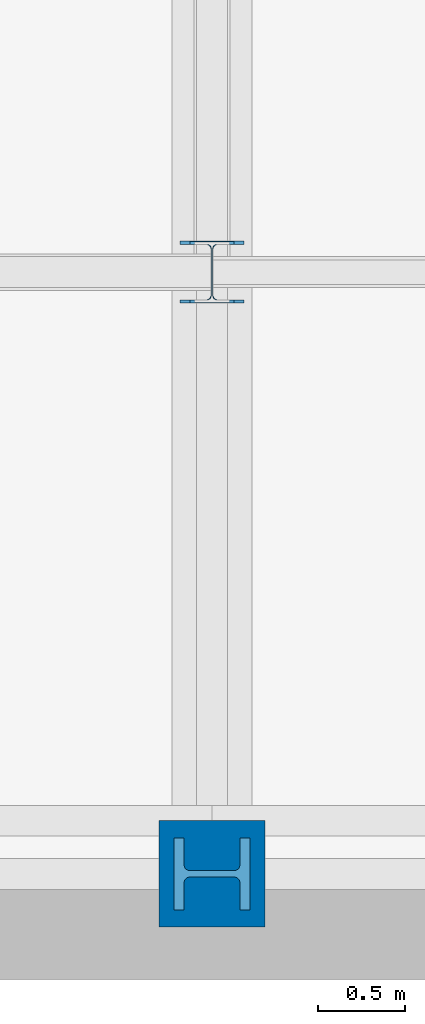
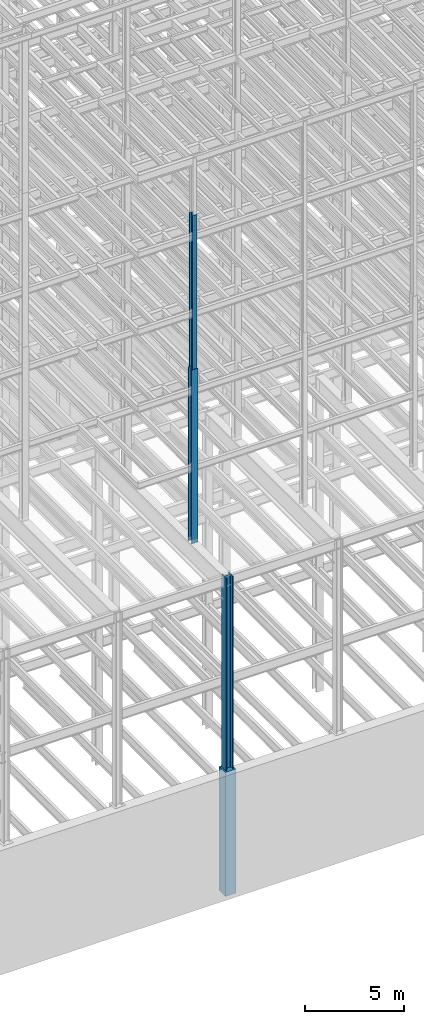
# One storey, part 3 of 150: 4 columns.
"""IFC2X3 building model written with IfcOpenShell, lengths in millimetres."""

from ifc_helpers import new_model, si_unit, frame, origin_with_axes, origin_2d_with_axis, place, context, subcontext, project, spatial, rectangle, i_section, extrude, material, type_object, element, save


model = new_model("IFC2X3")

# Units and contexts
model_context = context("Model", 3, precision=1e-05, world=origin_with_axes())
body_context = subcontext(model_context, "Body", "Model", "MODEL_VIEW")
ifc_project = project(units=[si_unit("LENGTHUNIT", "METRE", prefix="MILLI"), si_unit("AREAUNIT", "SQUARE_METRE"), si_unit("VOLUMEUNIT", "CUBIC_METRE"), si_unit("MASSUNIT", "GRAM", prefix="KILO"), si_unit("TIMEUNIT", "SECOND"), si_unit("PLANEANGLEUNIT", "RADIAN"), si_unit("SOLIDANGLEUNIT", "STERADIAN"), si_unit("THERMODYNAMICTEMPERATUREUNIT", "DEGREE_CELSIUS"), si_unit("LUMINOUSINTENSITYUNIT", "LUMEN")], contexts=[model_context])

# Site, building, storey
site_placement = place(None, origin_with_axes())
site = spatial("IfcSite", under=ifc_project, at=site_placement, CompositionType="ELEMENT")
building_placement = place(site_placement, origin_with_axes())
building = spatial("IfcBuilding", under=site, at=building_placement, Name="Undefined", CompositionType="ELEMENT")
storey_placement = place(building_placement, origin_with_axes())
storey = spatial("IfcBuildingStorey", under=building, at=storey_placement, Name="Undefined", CompositionType="ELEMENT", Elevation=0.0)

# Columns
ifc_material_1 = material(Name="STEEL/A992")
column_type_1 = type_object("IfcColumnType", Name="W14X61", PredefinedType="NOTDEFINED")
column_1_placement = place(storey_placement, frame((18186.4, 3454.4, 46253.4), z_axis=(0.0, 0.0, 1.0), x_axis=(1.0, 0.0, 0.0)))
element("IfcColumn", 1, at=column_1_placement, inside=storey, type_object=column_type_1, material=ifc_material_1, Name="COLUMN", ObjectType="W14X61", context=body_context, shape_type="SweptSolid", body=[
    extrude(i_section(OverallWidth=254.0, OverallDepth=352.425, WebThickness=9.5249, FlangeThickness=16.383, FilletRadius=21.717, at=origin_2d_with_axis()), frame((0.0, 0.0, 9448.8), z_axis=(0.0, 0.0, -1.0), x_axis=(-1.0, 0.0, 0.0)), (0.0, 0.0, 1.0), 9448.8),
])
column_type_2 = type_object("IfcColumnType", Name="W14X311", PredefinedType="NOTDEFINED")
column_2_placement = place(storey_placement, frame((18186.4, 0.0, 22707.6), z_axis=(0.0, 0.0, 1.0), x_axis=(1.0, 0.0, 0.0)))
element("IfcColumn", 2, at=column_2_placement, inside=storey, type_object=column_type_2, material=ifc_material_1, Name="COLUMN", ObjectType="W14X311", context=body_context, shape_type="SweptSolid", body=[
    extrude(i_section(OverallWidth=412.75, OverallDepth=434.975, WebThickness=36.5125, FlangeThickness=57.404, FilletRadius=33.0834, at=origin_2d_with_axis()), frame((0.0, 0.0, 12877.8), z_axis=(0.0, 0.0, -1.0), x_axis=(0.0, -1.0, 0.0)), (0.0, 0.0, 1.0), 12877.8),
])
column_type_3 = type_object("IfcColumnType", Name="W14X90", PredefinedType="NOTDEFINED")
column_3_placement = place(storey_placement, frame((18186.4, 3454.4, 35585.4), z_axis=(0.0, 0.0, 1.0), x_axis=(1.0, 0.0, 0.0)))
element("IfcColumn", 3, at=column_3_placement, inside=storey, type_object=column_type_3, material=ifc_material_1, Name="COLUMN", ObjectType="W14X90", context=body_context, shape_type="SweptSolid", body=[
    extrude(i_section(OverallWidth=368.3, OverallDepth=355.6, WebThickness=11.1125, FlangeThickness=18.034, FilletRadius=32.7659, at=origin_2d_with_axis()), frame((0.0, 0.0, 10668.0), z_axis=(0.0, 0.0, -1.0), x_axis=(-1.0, 0.0, 0.0)), (0.0, 0.0, 1.0), 10668.0),
])
ifc_material_2 = material(Name="CONCRETE/5000")
column_type_4 = type_object("IfcColumnType", PredefinedType="NOTDEFINED")
column_4_placement = place(storey_placement, frame((18186.4, 0.0, 16154.4), z_axis=(0.0, 0.0, 1.0), x_axis=(1.0, 0.0, 0.0)))
element("IfcColumn", 4, at=column_4_placement, inside=storey, type_object=column_type_4, material=ifc_material_2, Name="COLUMN", context=body_context, shape_type="SweptSolid", body=[
    extrude(rectangle(XDim=609.6, YDim=609.6, at=origin_2d_with_axis()), frame((0.0, 0.0, 7620.0), z_axis=(0.0, 0.0, -1.0), x_axis=(0.0, -1.0, 0.0)), (0.0, 0.0, 1.0), 7620.0),
])

save(model, "model.ifc")
